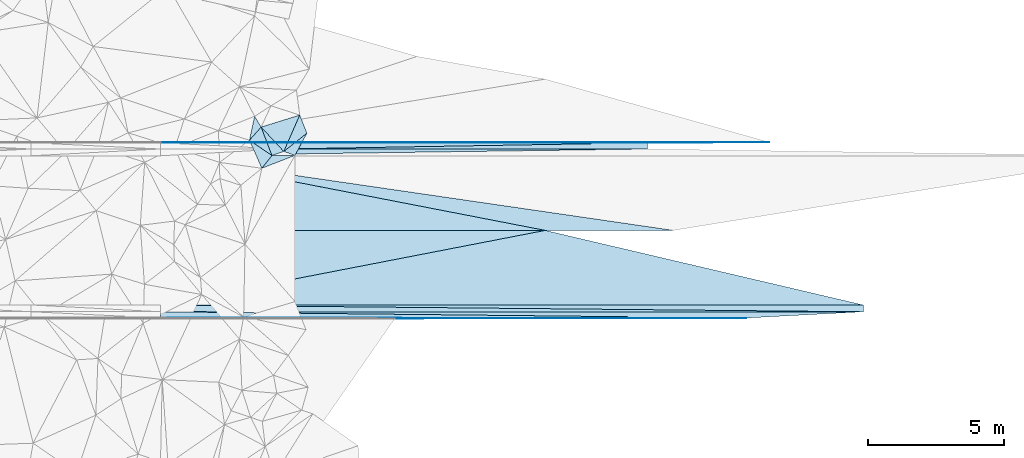
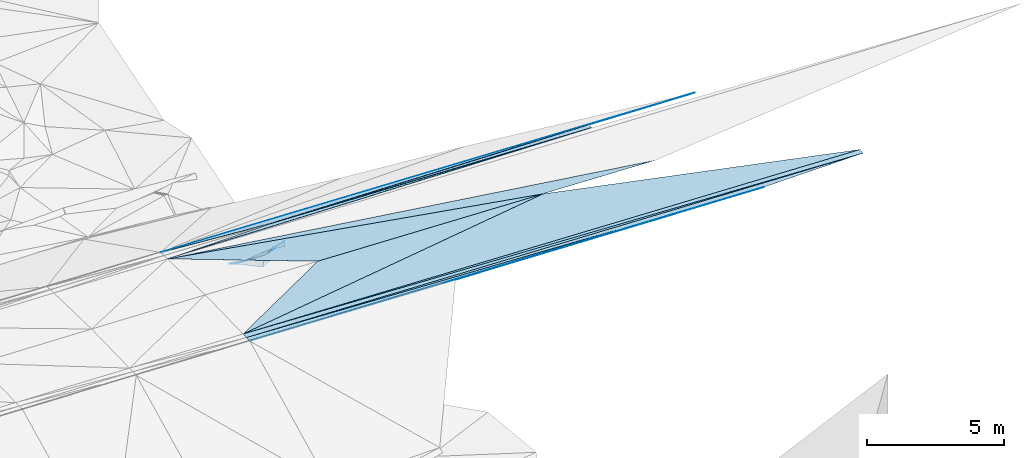
# One storey, part 107 of 275: 22 plates.
"""IFC2X3 building model written with IfcOpenShell, lengths in millimetres."""

from ifc_helpers import new_model, si_unit, frame, origin_with_axes, place, context, subcontext, project, spatial, polyline, outline, extrude, material, type_object, element, save


model = new_model("IFC2X3")

# Units and contexts
model_context = context("Model", 3, precision=1e-05, world=origin_with_axes())
body_context = subcontext(model_context, "Body", "Model", "MODEL_VIEW")
ifc_project = project(units=[si_unit("LENGTHUNIT", "METRE", prefix="MILLI"), si_unit("AREAUNIT", "SQUARE_METRE"), si_unit("VOLUMEUNIT", "CUBIC_METRE"), si_unit("MASSUNIT", "GRAM", prefix="KILO"), si_unit("TIMEUNIT", "SECOND"), si_unit("PLANEANGLEUNIT", "RADIAN"), si_unit("SOLIDANGLEUNIT", "STERADIAN"), si_unit("THERMODYNAMICTEMPERATUREUNIT", "DEGREE_CELSIUS"), si_unit("LUMINOUSINTENSITYUNIT", "LUMEN")], contexts=[model_context])

# Site, building, storey
site_placement = place(None, origin_with_axes())
site = spatial("IfcSite", under=ifc_project, at=site_placement, CompositionType="ELEMENT")
building_placement = place(site_placement, origin_with_axes())
building = spatial("IfcBuilding", under=site, at=building_placement, Name="Undefined", CompositionType="ELEMENT")
storey_placement = place(building_placement, origin_with_axes())
storey = spatial("IfcBuildingStorey", under=building, at=storey_placement, Name="Undefined", CompositionType="ELEMENT", Elevation=0.0)

# Plates
ifc_material = material()
plate_type_1 = type_object("IfcPlateType", PredefinedType="NOTDEFINED")
plate_1_placement = place(storey_placement, frame((-8246.56713992195, 60537.3750470916, 47212.5064452482), z_axis=(-0.0338571161760964, 0.0249801178898649, -0.999114452600125), x_axis=(-0.999426275850819, 5.723397562415e-05, 0.0338690989433678)))
element("IfcPlate", 1, at=plate_1_placement, inside=storey, type_object=plate_type_1, material=ifc_material, Name="00_PR", context=body_context, shape_type="SweptSolid", body=[
    extrude(outline(polyline([(0.0, 0.0), (25926.24609375, -9.67702362686396e-10), (11738.865234375, 2750.85864257813), (0.0, 0.0)])), frame((-8.85201319254618e-08, 2.18876761149539e-07, -0.5000001331573), z_axis=(0.0, 0.0, 1.0), x_axis=(1.0, 0.0, 0.0)), (0.0, 0.0, 1.0), 1.0),
])
plate_type_2 = type_object("IfcPlateType", PredefinedType="NOTDEFINED")
plate_2_placement = place(storey_placement, frame((-8246.58146371028, 60287.3750450848, 47206.2734452516), z_axis=(-0.0338564616727785, 0.0249798021392035, -0.999114482673575), x_axis=(-0.999426275850819, 5.723397562415e-05, 0.0338690989433678)))
element("IfcPlate", 2, at=plate_2_placement, inside=storey, type_object=plate_type_2, material=ifc_material, Name="00_PR", context=body_context, shape_type="SweptSolid", body=[
    extrude(outline(polyline([(0.0, 0.0), (25926.244140625, -8.57035047374666e-08), (25926.45703125, 250.078018188477), (0.0, 0.0)])), frame((-8.85201319254618e-08, 2.18876761149539e-07, -0.5000001331573), z_axis=(0.0, 0.0, 1.0), x_axis=(1.0, 0.0, 0.0)), (0.0, 0.0, 1.0), 1.0),
])
plate_3_placement = place(storey_placement, frame((-34157.9381099204, 60538.8599102518, 48090.605442538), z_axis=(-0.0338571777340721, 0.0249119037314795, -0.99911615369203), x_axis=(0.999426275850804, -5.72339860804832e-05, -0.0338690989437899)))
element("IfcPlate", 3, at=plate_3_placement, inside=storey, type_object=plate_type_2, material=ifc_material, Name="00_PR", context=body_context, shape_type="SweptSolid", body=[
    extrude(outline(polyline([(0.0, 0.0), (25926.24609375, -9.67702362686396e-10), (25926.45703125, 250.077606201172), (0.0, 0.0)])), frame((-8.85201319254618e-08, 2.18876761149539e-07, -0.5000001331573), z_axis=(0.0, 0.0, 1.0), x_axis=(1.0, 0.0, 0.0)), (0.0, 0.0, 1.0), 1.0),
])
plate_type_3 = type_object("IfcPlateType", PredefinedType="NOTDEFINED")
plate_4_placement = place(storey_placement, frame((-16201.9096431438, 66517.7939617247, 47464.3639128322), z_axis=(-0.0338297481142317, -0.0499071816828997, -0.998180755854869), x_axis=(-0.999426275850819, 5.723397562415e-05, 0.0338690989433678)))
element("IfcPlate", 4, at=plate_4_placement, inside=storey, type_object=plate_type_3, material=ifc_material, Name="00_PR", context=body_context, shape_type="SweptSolid", body=[
    extrude(outline(polyline([(0.0, 0.0), (17965.994140625, -5.59375621378422e-08), (17965.958984375, 20.0252799987793), (0.0, 0.0)])), frame((-8.85201319254618e-08, 2.18876761149539e-07, -0.5000001331573), z_axis=(0.0, 0.0, 1.0), x_axis=(1.0, 0.0, 0.0)), (0.0, 0.0, 1.0), 1.0),
])
plate_5_placement = place(storey_placement, frame((-11712.9872910211, 66537.5357737268, 47311.2409123525), z_axis=(-0.0338297469902423, -0.0499095101179917, -0.998180639472815), x_axis=(-0.999409062928648, -0.00439529702322576, 0.0340911469469653)))
element("IfcPlate", 5, at=plate_5_placement, inside=storey, type_object=plate_type_3, material=ifc_material, Name="00_PR", context=body_context, shape_type="SweptSolid", body=[
    extrude(outline(polyline([(0.0, 0.0), (4491.57666015625, -4.46016201749444e-09), (22457.267578125, 100.118881225586), (0.0, 0.0)])), frame((-8.85201319254618e-08, 2.18876761149539e-07, -0.5000001331573), z_axis=(0.0, 0.0, 1.0), x_axis=(1.0, 0.0, 0.0)), (0.0, 0.0, 1.0), 1.0),
])
plate_6_placement = place(storey_placement, frame((-34157.9656502031, 60058.8727162344, 48072.8559096267), z_axis=(-0.0338240896261642, 0.0498814894603644, -0.998182231844555), x_axis=(0.999426275850804, -5.72339860804832e-05, -0.0338690989437899)))
element("IfcPlate", 6, at=plate_6_placement, inside=storey, type_object=plate_type_3, material=ifc_material, Name="00_PR", context=body_context, shape_type="SweptSolid", body=[
    extrude(outline(polyline([(0.0, 0.0), (21605.205078125, -4.67989593744278e-08), (8642.115234375, 20.0249671936035), (0.0, 0.0)])), frame((-8.85201319254618e-08, 2.18876761149539e-07, -0.5000001331573), z_axis=(0.0, 0.0, 1.0), x_axis=(1.0, 0.0, 0.0)), (0.0, 0.0, 1.0), 1.0),
])
plate_type_4 = type_object("IfcPlateType", PredefinedType="NOTDEFINED")
plate_7_placement = place(storey_placement, frame((-34157.5954179052, 66518.8222199266, 48072.8559119787), z_axis=(-0.0338297481142317, -0.0499071816828997, -0.998180755854869), x_axis=(0.999426275850804, -5.72339860804832e-05, -0.0338690989437899)))
element("IfcPlate", 7, at=plate_7_placement, inside=storey, type_object=plate_type_4, material=ifc_material, Name="00_PR", context=body_context, shape_type="SweptSolid", body=[
    extrude(outline(polyline([(0.0, 0.0), (17965.994140625, -5.59375621378422e-08), (4491.10888671875, 230.286804199219), (0.0, 0.0)])), frame((-8.85201319254618e-08, 2.18876761149539e-07, -0.5000001331573), z_axis=(0.0, 0.0, 1.0), x_axis=(1.0, 0.0, 0.0)), (0.0, 0.0, 1.0), 1.0),
])
plate_8_placement = place(storey_placement, frame((-16201.9096431438, 66517.7939617247, 47464.3639128322), z_axis=(-0.0338297481142317, -0.0499071816828997, -0.998180755854869), x_axis=(-5.57099735653163e-05, -0.998752343725082, 0.0499374889242045)))
element("IfcPlate", 8, at=plate_8_placement, inside=storey, type_object=plate_type_4, material=ifc_material, Name="00_PR", context=body_context, shape_type="SweptSolid", body=[
    extrude(outline(polyline([(0.0, 0.0), (230.28791809082, 9.89530235528946e-10), (253.057022094727, 13474.4755859375), (0.0, 0.0)])), frame((-8.85201319254618e-08, 2.18876761149539e-07, -0.5000001331573), z_axis=(0.0, 0.0, 1.0), x_axis=(1.0, 0.0, 0.0)), (0.0, 0.0, 1.0), 1.0),
])
plate_9_placement = place(storey_placement, frame((-12565.1559855034, 60057.6353681584, 47341.1069115375), z_axis=(-0.0338240379099018, 0.0499110544094614, -0.998180755728744), x_axis=(-0.999426275850819, 5.723397562415e-05, 0.0338690989433678)))
element("IfcPlate", 9, at=plate_9_placement, inside=storey, type_object=plate_type_4, material=ifc_material, Name="00_PR", context=body_context, shape_type="SweptSolid", body=[
    extrude(outline(polyline([(0.0, 0.0), (21605.205078125, -4.67989593744278e-08), (21605.59375, 230.286666870117), (0.0, 0.0)])), frame((-8.85201319254618e-08, 2.18876761149539e-07, -0.5000001331573), z_axis=(0.0, 0.0, 1.0), x_axis=(1.0, 0.0, 0.0)), (0.0, 0.0, 1.0), 1.0),
])
plate_10_placement = place(storey_placement, frame((-34157.9524166844, 60288.8724392639, 48084.3559114782), z_axis=(-0.0338232856427307, 0.0499715970742942, -0.998177752123426), x_axis=(0.999426275850804, -5.72339860804832e-05, -0.0338690989437899)))
element("IfcPlate", 10, at=plate_10_placement, inside=storey, type_object=plate_type_4, material=ifc_material, Name="00_PR", context=body_context, shape_type="SweptSolid", body=[
    extrude(outline(polyline([(0.0, 0.0), (25926.244140625, -8.57035047374666e-08), (21605.59375, 230.287322998047), (0.0, 0.0)])), frame((-8.85201319254618e-08, 2.18876761149539e-07, -0.5000001331573), z_axis=(0.0, 0.0, 1.0), x_axis=(1.0, 0.0, 0.0)), (0.0, 0.0, 1.0), 1.0),
])
plate_type_5 = type_object("IfcPlateType", PredefinedType="NOTDEFINED")
plate_11_placement = place(storey_placement, frame((-34157.6229937409, 66038.8350071046, 48090.6054438255), z_axis=(-0.0338599635667188, -0.0249758570214547, -0.999114462628434), x_axis=(0.99783703537855, 0.0555148520456819, -0.0352044319552634)))
element("IfcPlate", 11, at=plate_11_placement, inside=storey, type_object=plate_type_5, material=ifc_material, Name="00_PR", context=body_context, shape_type="SweptSolid", body=[
    extrude(outline(polyline([(0.0, 0.0), (4498.66650390625, -3.66708263754845e-09), (17952.326171875, 749.0390625), (0.0, 0.0)])), frame((-8.85201319254618e-08, 2.18876761149539e-07, -0.5000001331573), z_axis=(0.0, 0.0, 1.0), x_axis=(1.0, 0.0, 0.0)), (0.0, 0.0, 1.0), 1.0),
])
plate_type_6 = type_object("IfcPlateType", PredefinedType="NOTDEFINED")
plate_12_placement = place(storey_placement, frame((-15249.0238504524, 63287.7511011167, 47518.5654451202), z_axis=(-0.0338599635667188, -0.0249758570214547, -0.999114462628434), x_axis=(-0.999426275850819, 5.723397562415e-05, 0.0338690989433678)))
element("IfcPlate", 12, at=plate_12_placement, inside=storey, type_object=plate_type_6, material=ifc_material, Name="00_PR", context=body_context, shape_type="SweptSolid", body=[
    extrude(outline(polyline([(0.0, 0.0), (4729.90283203125, 4.125467967242e-09), (18917.283203125, 2750.85571289063), (0.0, 0.0)])), frame((-8.85201319254618e-08, 2.18876761149539e-07, -0.5000001331573), z_axis=(0.0, 0.0, 1.0), x_axis=(1.0, 0.0, 0.0)), (0.0, 0.0, 1.0), 1.0),
])
plate_type_7 = type_object("IfcPlateType", PredefinedType="NOTDEFINED")
plate_13_placement = place(storey_placement, frame((-19976.2127703734, 63288.0227324371, 47678.7634445693), z_axis=(-0.0338599635667188, -0.0249758570214547, -0.999114462628434), x_axis=(-0.999426275850819, 5.723397562415e-05, 0.0338690989433678)))
element("IfcPlate", 13, at=plate_13_placement, inside=storey, type_object=plate_type_7, material=ifc_material, Name="00_PR", context=body_context, shape_type="SweptSolid", body=[
    extrude(outline(polyline([(0.0, 0.0), (9459.806640625, 1.37442839331925e-08), (14187.3798828125, 2750.85815429688), (0.0, 0.0)])), frame((-8.85201319254618e-08, 2.18876761149539e-07, -0.5000001331573), z_axis=(0.0, 0.0, 1.0), x_axis=(1.0, 0.0, 0.0)), (0.0, 0.0, 1.0), 1.0),
])
plate_14_placement = place(storey_placement, frame((-29430.5920338968, 63288.5892475849, 47999.1584436254), z_axis=(-0.0338571161760964, 0.0249801178898649, -0.999114452600125), x_axis=(0.999426275850804, -5.72339860804832e-05, -0.0338690989437899)))
element("IfcPlate", 14, at=plate_14_placement, inside=storey, type_object=plate_type_7, material=ifc_material, Name="00_PR", context=body_context, shape_type="SweptSolid", body=[
    extrude(outline(polyline([(0.0, 0.0), (9459.806640625, 1.37442839331925e-08), (-4727.57373046875, 2750.8583984375), (0.0, 0.0)])), frame((-8.85201319254618e-08, 2.18876761149539e-07, -0.5000001331573), z_axis=(0.0, 0.0, 1.0), x_axis=(1.0, 0.0, 0.0)), (0.0, 0.0, 1.0), 1.0),
])
plate_type_8 = type_object("IfcPlateType", PredefinedType="NOTDEFINED")
plate_15_placement = place(storey_placement, frame((-28764.5866935215, 66869.2299864094, 46449.546952612), z_axis=(-0.15917039982687, -0.391965113113381, -0.906106027968564), x_axis=(-0.42814209295775, -0.799603813133174, 0.421103419910888)))
element("IfcPlate", 15, at=plate_15_placement, inside=storey, type_object=plate_type_8, material=ifc_material, Name="00", context=body_context, shape_type="SweptSolid", body=[
    extrude(outline(polyline([(0.0, 0.0), (1021.12683105469, -4.38012648373842e-09), (1086.64270019531, 433.829071044922), (0.0, 0.0)])), frame((-8.85201319254618e-08, 2.18876761149539e-07, -0.5000001331573), z_axis=(0.0, 0.0, 1.0), x_axis=(1.0, 0.0, 0.0)), (0.0, 0.0, 1.0), 1.0),
])
plate_type_9 = type_object("IfcPlateType", PredefinedType="NOTDEFINED")
plate_16_placement = place(storey_placement, frame((-30450.3955905746, 67096.8850188474, 46029.5925859547), z_axis=(0.315524095426372, -0.486334691602479, -0.814814772171744), x_axis=(0.557182268268674, -0.600111705725198, 0.573945869031713)))
element("IfcPlate", 16, at=plate_16_placement, inside=storey, type_object=plate_type_9, material=ifc_material, Name="00", context=body_context, shape_type="SweptSolid", body=[
    extrude(outline(polyline([(0.0, 0.0), (1498.39916992188, 4.89671947434545e-09), (1298.71936035156, 423.943389892578), (0.0, 0.0)])), frame((-8.85201319254618e-08, 2.18876761149539e-07, -0.5000001331573), z_axis=(0.0, 0.0, 1.0), x_axis=(1.0, 0.0, 0.0)), (0.0, 0.0, 1.0), 1.0),
])
plate_type_10 = type_object("IfcPlateType", PredefinedType="NOTDEFINED")
plate_17_placement = place(storey_placement, frame((-29201.6547580782, 66053.0225927497, 46879.5104215051), z_axis=(0.0795815406881168, 0.186930737989617, -0.979144359926749), x_axis=(-0.922517037913671, -0.358332089605617, -0.143389080190434)))
element("IfcPlate", 17, at=plate_17_placement, inside=storey, type_object=plate_type_10, material=ifc_material, Name="00", context=body_context, shape_type="SweptSolid", body=[
    extrude(outline(polyline([(0.0, 0.0), (1325.06604003906, 2.61934474110603e-10), (796.564086914063, 307.222503662109), (0.0, 0.0)])), frame((-8.85201319254618e-08, 2.18876761149539e-07, -0.5000001331573), z_axis=(0.0, 0.0, 1.0), x_axis=(1.0, 0.0, 0.0)), (0.0, 0.0, 1.0), 1.0),
])
plate_type_11 = type_object("IfcPlateType", PredefinedType="NOTDEFINED")
plate_18_placement = place(storey_placement, frame((-29028.0904919399, 67539.7189569527, 45659.6636895964), z_axis=(0.211705367477179, -0.709069569111084, -0.672607748648478), x_axis=(0.246600076268535, -0.627184319944143, 0.738801889007165)))
element("IfcPlate", 18, at=plate_18_placement, inside=storey, type_object=plate_type_11, material=ifc_material, Name="00", context=body_context, shape_type="SweptSolid", body=[
    extrude(outline(polyline([(0.0, 0.0), (1069.298828125, 1.70985003933311e-09), (1605.63159179688, 1039.87841796875), (0.0, 0.0)])), frame((-8.85201319254618e-08, 2.18876761149539e-07, -0.5000001331573), z_axis=(0.0, 0.0, 1.0), x_axis=(1.0, 0.0, 0.0)), (0.0, 0.0, 1.0), 1.0),
])
plate_type_12 = type_object("IfcPlateType", PredefinedType="NOTDEFINED")
plate_19_placement = place(storey_placement, frame((-29615.6612070088, 66197.5810412466, 46889.6338026319), z_axis=(0.0214216989963008, -0.680558381703636, -0.732380638674344), x_axis=(-0.557182268270981, 0.600111705723526, -0.573945869031223)))
element("IfcPlate", 19, at=plate_19_placement, inside=storey, type_object=plate_type_12, material=ifc_material, Name="00", context=body_context, shape_type="SweptSolid", body=[
    extrude(outline(polyline([(0.0, 0.0), (1498.39916992188, 4.89671947434545e-09), (1184.06372070313, 1502.46240234375), (0.0, 0.0)])), frame((-8.85201319254618e-08, 2.18876761149539e-07, -0.5000001331573), z_axis=(0.0, 0.0, 1.0), x_axis=(1.0, 0.0, 0.0)), (0.0, 0.0, 1.0), 1.0),
])
plate_type_13 = type_object("IfcPlateType", PredefinedType="NOTDEFINED")
plate_20_placement = place(storey_placement, frame((-30880.7914252121, 66611.573143711, 46369.5476085492), z_axis=(0.414761923432998, -0.0967753870259776, -0.904769070722542), x_axis=(0.757200272091983, -0.514694152482758, 0.402166230984007)))
element("IfcPlate", 20, at=plate_20_placement, inside=storey, type_object=plate_type_13, material=ifc_material, Name="00", context=body_context, shape_type="SweptSolid", body=[
    extrude(outline(polyline([(0.0, 0.0), (1094.07495117188, 3.22688720189035e-09), (1006.60382080078, 605.019653320313), (0.0, 0.0)])), frame((-8.85201319254618e-08, 2.18876761149539e-07, -0.5000001331573), z_axis=(0.0, 0.0, 1.0), x_axis=(1.0, 0.0, 0.0)), (0.0, 0.0, 1.0), 1.0),
])
plate_type_14 = type_object("IfcPlateType", PredefinedType="NOTDEFINED")
plate_21_placement = place(storey_placement, frame((-30691.4473037752, 67493.3119602264, 45779.5827998991), z_axis=(-0.0389320896750252, -0.549803392045282, -0.834386314897984), x_axis=(0.457091196326139, -0.752332785708165, 0.474408070957622)))
element("IfcPlate", 21, at=plate_21_placement, inside=storey, type_object=plate_type_14, material=ifc_material, Name="00", context=body_context, shape_type="SweptSolid", body=[
    extrude(outline(polyline([(0.0, 0.0), (526.972473144531, 9.6588337328285e-10), (856.781005859375, 654.084350585938), (0.0, 0.0)])), frame((-8.85201319254618e-08, 2.18876761149539e-07, -0.5000001331573), z_axis=(0.0, 0.0, 1.0), x_axis=(1.0, 0.0, 0.0)), (0.0, 0.0, 1.0), 1.0),
])
plate_type_15 = type_object("IfcPlateType", PredefinedType="NOTDEFINED")
plate_22_placement = place(storey_placement, frame((-30052.5510793267, 66048.2126530318, 46809.5964559854), z_axis=(0.027750757356482, -0.589797244889098, -0.807074411307514), x_axis=(-0.757200272090322, 0.514694152486334, -0.402166230982558)))
element("IfcPlate", 22, at=plate_22_placement, inside=storey, type_object=plate_type_15, material=ifc_material, Name="00", context=body_context, shape_type="SweptSolid", body=[
    extrude(outline(polyline([(0.0, 0.0), (1094.07495117188, 3.22688720189035e-09), (1154.76550292969, 730.011413574219), (0.0, 0.0)])), frame((-8.85201319254618e-08, 2.18876761149539e-07, -0.5000001331573), z_axis=(0.0, 0.0, 1.0), x_axis=(1.0, 0.0, 0.0)), (0.0, 0.0, 1.0), 1.0),
])

save(model, "model.ifc")
